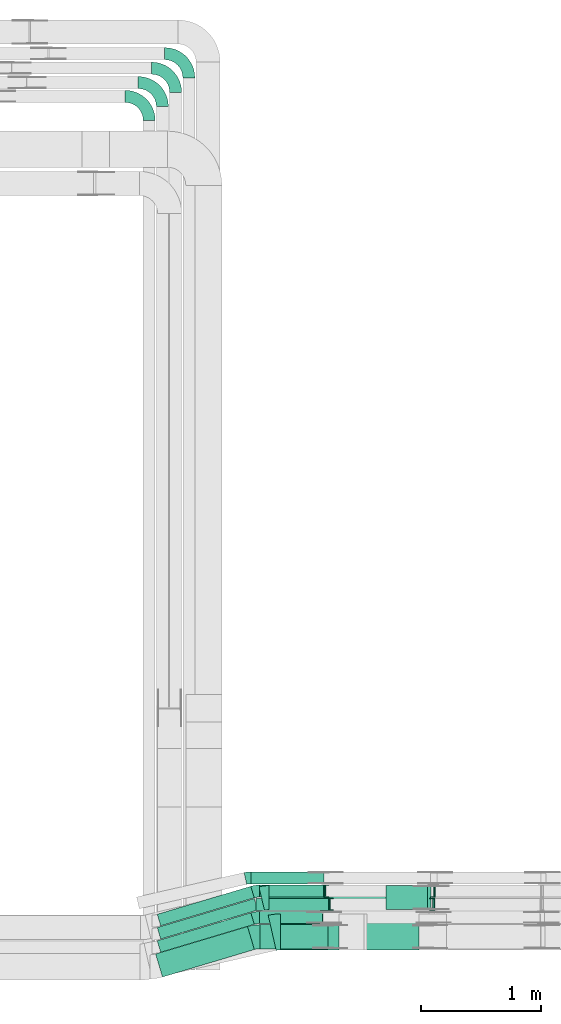
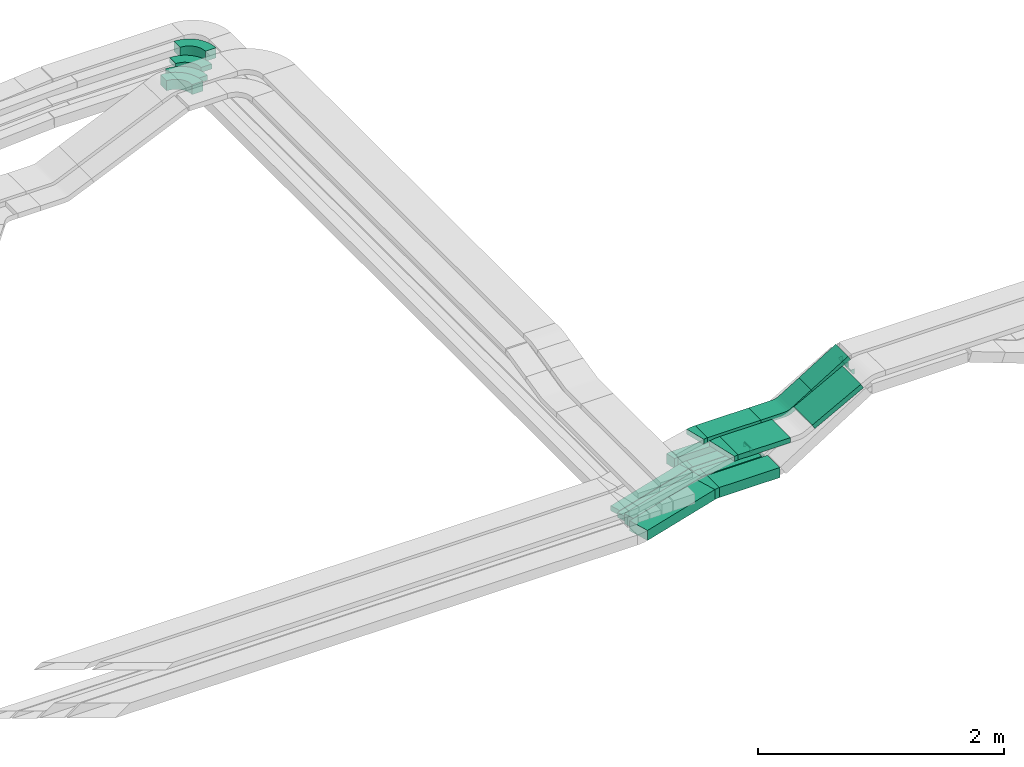
# One storey, part 22 of 28: 15 flow fittings, 13 flow segments.
"""IFC2X3 building model written with IfcOpenShell, lengths in millimetres."""

from ifc_helpers import new_model, entity, si_unit, converted_unit, derived_unit, direction, frame, frame_2d, origin, origin_2d_with_axis, place, context, subcontext, project, spatial, polyline, circle_curve, parameter, trimmed, segment, composite_curve, rectangle, outline, extrude, faceted_brep, source, transform, mapped, material, type_object, type_shapes, element, save


model = new_model("IFC2X3")

# Units and contexts
model_context = context("Model", 3, precision=0.01, world=origin(), true_north=direction((6.12303176911189e-17, 1.0)))
body_context = subcontext(model_context, "Body", "Model", "MODEL_VIEW")
ifc_project = project(units=[si_unit("LENGTHUNIT", "METRE", prefix="MILLI"), si_unit("AREAUNIT", "SQUARE_METRE"), si_unit("VOLUMEUNIT", "CUBIC_METRE"), converted_unit("PLANEANGLEUNIT", "DEGREE", entity("IfcRatioMeasure", 0.0174532925199433), si_unit("PLANEANGLEUNIT", "RADIAN"), dimensions=[0, 0, 0, 0, 0, 0, 0]), si_unit("MASSUNIT", "GRAM", prefix="KILO"), derived_unit("MASSDENSITYUNIT", [(si_unit("MASSUNIT", "GRAM", prefix="KILO"), 1), (si_unit("LENGTHUNIT", "METRE"), -3)]), derived_unit("MOMENTOFINERTIAUNIT", [(si_unit("LENGTHUNIT", "METRE"), 4)]), si_unit("TIMEUNIT", "SECOND"), si_unit("FREQUENCYUNIT", "HERTZ"), si_unit("THERMODYNAMICTEMPERATUREUNIT", "DEGREE_CELSIUS"), derived_unit("THERMALTRANSMITTANCEUNIT", [(si_unit("MASSUNIT", "GRAM", prefix="KILO"), 1), (si_unit("THERMODYNAMICTEMPERATUREUNIT", "KELVIN"), -1), (si_unit("TIMEUNIT", "SECOND"), -3)]), derived_unit("VOLUMETRICFLOWRATEUNIT", [(si_unit("LENGTHUNIT", "METRE"), 3), (si_unit("TIMEUNIT", "SECOND"), -1)]), derived_unit("MASSFLOWRATEUNIT", [(si_unit("MASSUNIT", "GRAM", prefix="KILO"), 1), (si_unit("TIMEUNIT", "SECOND"), -1)]), derived_unit("ROTATIONALFREQUENCYUNIT", [(si_unit("TIMEUNIT", "SECOND"), -1)]), si_unit("ELECTRICCURRENTUNIT", "AMPERE"), si_unit("ELECTRICVOLTAGEUNIT", "VOLT"), si_unit("POWERUNIT", "WATT"), si_unit("FORCEUNIT", "NEWTON", prefix="KILO"), si_unit("ILLUMINANCEUNIT", "LUX"), si_unit("LUMINOUSFLUXUNIT", "LUMEN"), si_unit("LUMINOUSINTENSITYUNIT", "CANDELA"), derived_unit("USERDEFINED", [(si_unit("MASSUNIT", "GRAM", prefix="KILO"), -1), (si_unit("LENGTHUNIT", "METRE"), -2), (si_unit("TIMEUNIT", "SECOND"), 3), (si_unit("LUMINOUSFLUXUNIT", "LUMEN"), 1)]), derived_unit("LINEARVELOCITYUNIT", [(si_unit("LENGTHUNIT", "METRE"), 1), (si_unit("TIMEUNIT", "SECOND"), -1)]), si_unit("PRESSUREUNIT", "PASCAL"), derived_unit("USERDEFINED", [(si_unit("LENGTHUNIT", "METRE"), -2), (si_unit("MASSUNIT", "GRAM", prefix="KILO"), 1), (si_unit("TIMEUNIT", "SECOND"), -2)]), derived_unit("LINEARFORCEUNIT", [(si_unit("MASSUNIT", "GRAM", prefix="KILO"), 1), (si_unit("LENGTHUNIT", "METRE"), 1), (si_unit("TIMEUNIT", "SECOND"), -2), (si_unit("LENGTHUNIT", "METRE"), -1)]), derived_unit("PLANARFORCEUNIT", [(si_unit("MASSUNIT", "GRAM", prefix="KILO"), 1), (si_unit("LENGTHUNIT", "METRE"), 1), (si_unit("TIMEUNIT", "SECOND"), -2), (si_unit("LENGTHUNIT", "METRE"), -2)])], contexts=[model_context])

# Site, building, storey
site_placement = place(None, origin())
site = spatial("IfcSite", under=ifc_project, at=site_placement, CompositionType="ELEMENT")
building_placement = place(site_placement, origin())
building = spatial("IfcBuilding", under=site, at=building_placement, CompositionType="ELEMENT")
storey_placement = place(building_placement, frame((0.0, 0.0, 15900.0)))
storey = spatial("IfcBuildingStorey", under=building, at=storey_placement, CompositionType="ELEMENT", Elevation=15900.0)

# Flow segments
cable_carrier_segment_type = type_object("IfcCableCarrierSegmentType", PredefinedType="CABLETRAYSEGMENT")
flow_segment_1_placement = place(storey_placement, frame((60243.14, 8665.73, 2495.02)))
element("IfcFlowSegment", 1, at=flow_segment_1_placement, inside=storey, type_object=cable_carrier_segment_type, context=body_context, shape_type="SweptSolid", body=[
    extrude(rectangle(XDim=812.342114695417, YDim=100.000000000006, at=origin_2d_with_axis()), frame((403.48, 164.24, 0.0), z_axis=(0.0, 0.0, 1.0), x_axis=(-0.95810498938811, -0.286417229421712, 0.0)), (0.0, 0.0, 1.0), 50.0000000000016),
])
flow_segment_2_placement = place(storey_placement, frame((60243.14, 8555.73, 2495.05)))
element("IfcFlowSegment", 2, at=flow_segment_2_placement, inside=storey, type_object=cable_carrier_segment_type, context=body_context, shape_type="SweptSolid", body=[
    extrude(rectangle(XDim=842.596647110519, YDim=100.000000000006, at=origin_2d_with_axis()), frame((417.97, 168.57, 0.0), z_axis=(0.0, 0.0, 1.0), x_axis=(0.9581049893881, 0.286417229421747, 0.0)), (0.0, 0.0, 1.0), 50.0000000000016),
])
flow_segment_3_placement = place(storey_placement, frame((60243.14, 8445.73, 2500.0)))
element("IfcFlowSegment", 3, at=flow_segment_3_placement, inside=storey, type_object=cable_carrier_segment_type, context=body_context, shape_type="SweptSolid", body=[
    extrude(rectangle(XDim=812.342114695347, YDim=100.000000000004, at=origin_2d_with_axis()), frame((403.48, 164.24, 0.0), z_axis=(0.0, 0.0, 1.0), x_axis=(-0.958104989388097, -0.286417229421757, 0.0)), (0.0, 0.0, 1.0), 99.9999999999989),
])
flow_segment_4_placement = place(storey_placement, frame((60229.55, 8239.92, 2500.0)))
element("IfcFlowSegment", 4, at=flow_segment_4_placement, inside=storey, type_object=cable_carrier_segment_type, context=body_context, shape_type="SweptSolid", body=[
    extrude(rectangle(XDim=797.71484848776, YDim=200.000000000007, at=origin_2d_with_axis()), frame((410.79, 210.05, 0.0), z_axis=(0.0, 0.0, 1.0), x_axis=(0.958104989388095, 0.286417229421762, 0.0)), (0.0, 0.0, 1.0), 99.9999999999989),
])
flow_segment_5_placement = place(storey_placement, frame((61095.01, 8904.97, 2495.02)))
element("IfcFlowSegment", 5, at=flow_segment_5_placement, inside=storey, type_object=cable_carrier_segment_type, context=body_context, shape_type="SweptSolid", body=[
    extrude(rectangle(XDim=534.84490584839, YDim=99.9999999999989, at=origin_2d_with_axis()), frame((267.42, 50.0, 0.0)), (0.0, 0.0, 1.0), 50.0000000000016),
])
flow_segment_6_placement = place(storey_placement, frame((61064.76, 8794.97, 2500.0)))
element("IfcFlowSegment", 6, at=flow_segment_6_placement, inside=storey, type_object=cable_carrier_segment_type, context=body_context, shape_type="SweptSolid", body=[
    extrude(rectangle(XDim=603.13391952185, YDim=100.000000000001, at=origin_2d_with_axis()), frame((301.57, 50.0, 0.0), z_axis=(0.0, 0.0, 1.0), x_axis=(-1.0, 0.0, 0.0)), (0.0, 0.0, 1.0), 50.0000000000016),
])
flow_segment_7_placement = place(storey_placement, frame((61095.01, 8684.97, 2500.0)))
element("IfcFlowSegment", 7, at=flow_segment_7_placement, inside=storey, type_object=cable_carrier_segment_type, context=body_context, shape_type="SweptSolid", body=[
    extrude(rectangle(XDim=521.540062553163, YDim=99.9999999999989, at=origin_2d_with_axis()), frame((260.77, 50.0, 0.0)), (0.0, 0.0, 1.0), 99.9999999999989),
])
flow_segment_8_placement = place(storey_placement, frame((61096.05, 8474.97, 2500.0)))
element("IfcFlowSegment", 8, at=flow_segment_8_placement, inside=storey, type_object=cable_carrier_segment_type, context=body_context, shape_type="SweptSolid", body=[
    extrude(rectangle(XDim=569.341253253551, YDim=200.0, at=origin_2d_with_axis()), frame((284.67, 100.0, 0.0), z_axis=(0.0, 0.0, 1.0), x_axis=(-1.0, 0.0, 0.0)), (0.0, 0.0, 1.0), 99.9999999999989),
])
flow_segment_9_placement = place(storey_placement, frame((61174.21, 8800.15, 2820.0)))
element("IfcFlowSegment", 9, at=flow_segment_9_placement, inside=storey, type_object=cable_carrier_segment_type, context=body_context, shape_type="SweptSolid", body=[
    extrude(rectangle(XDim=499.125355174538, YDim=200.0, at=origin_2d_with_axis()), frame((249.56, 100.0, 0.0)), (0.0, 0.0, 1.0), 50.0000000000016),
])
flow_segment_10_placement = place(storey_placement, frame((61267.59, 8465.15, 2820.0)))
element("IfcFlowSegment", 10, at=flow_segment_10_placement, inside=storey, type_object=cable_carrier_segment_type, context=body_context, shape_type="SweptSolid", body=[
    extrude(rectangle(XDim=489.342035058011, YDim=300.000000000001, at=origin_2d_with_axis()), frame((244.67, 150.0, 0.0)), (0.0, 0.0, 1.0), 50.0000000000016),
])
flow_segment_11_placement = place(storey_placement, frame((61022.43, 9014.97, 2500.0)))
element("IfcFlowSegment", 11, at=flow_segment_11_placement, inside=storey, type_object=cable_carrier_segment_type, context=body_context, shape_type="SweptSolid", body=[
    extrude(rectangle(XDim=607.951662645595, YDim=99.9999999999989, at=origin_2d_with_axis()), frame((303.98, 50.0, 0.0)), (0.0, 0.0, 1.0), 99.9999999999989),
])
flow_segment_12_placement = place(storey_placement, frame((62147.15, 8800.15, 2961.38)))
element("IfcFlowSegment", 12, at=flow_segment_12_placement, inside=storey, type_object=cable_carrier_segment_type, context=body_context, shape_type="SweptSolid", body=[
    extrude(rectangle(XDim=50.000000000001, YDim=200.0, at=origin_2d_with_axis()), frame((13.09, 100.0, 21.3), z_axis=(0.851940405089881, 0.0, 0.523638755417596), x_axis=(-0.523638755417596, 0.0, 0.851940405089881)), (0.0, 0.0, 1.0), 405.830197083303),
])
flow_segment_13_placement = place(storey_placement, frame((61963.27, 8465.15, 2877.86)))
element("IfcFlowSegment", 13, at=flow_segment_13_placement, inside=storey, type_object=cable_carrier_segment_type, context=body_context, shape_type="SweptSolid", body=[
    extrude(rectangle(XDim=49.9999999999993, YDim=299.999999999999, at=origin_2d_with_axis()), frame((11.83, 150.0, 22.02), z_axis=(0.880953567308328, 0.0, 0.473202717919848), x_axis=(-0.473202717919848, 0.0, 0.880953567308328)), (0.0, 0.0, 1.0), 518.229008882918),
])

# Flow fittings
ifc_material = material()
cable_carrier_fitting_type_1 = type_object("IfcCableCarrierFittingType", PredefinedType="NOTDEFINED", material=ifc_material)
shared_shape_1 = source(origin(), body_context, "Body", "Brep", [
    faceted_brep([(-14.14, 25.0, 50.0), (-14.14, 25.0, -50.0), (-14.14, -25.0, -50.0), (-14.14, -25.0, -47.46), (-14.14, 22.46, -47.46), (-14.14, 22.46, 47.46), (-14.14, -25.0, 47.46), (-14.14, -25.0, 50.0), (-1.05, 28.7, 50.0), (25.14, -13.9, 50.0), (25.14, -13.9, 47.46), (0.28, 26.54, 47.46), (0.28, 26.54, -47.46), (25.14, -13.9, -47.46), (25.14, -13.9, -50.0), (-1.05, 28.7, -50.0), (-7.07, 25.0, 50.0), (-7.07, 25.0, -50.0), (7.07, -25.0, -50.0), (7.07, -25.0, -47.46), (-6.35, 22.46, -47.46), (-6.35, 22.46, 47.46), (7.07, -25.0, 47.46), (7.07, -25.0, 50.0)], [[[0, 1, 2, 3, 4, 5, 6, 7]], [[8, 9, 10, 11, 12, 13, 14, 15]], [[1, 0, 16, 17]], [[2, 1, 17, 15, 14, 18]], [[3, 2, 18, 19]], [[4, 3, 19, 13, 12, 20]], [[5, 4, 20, 21]], [[6, 5, 21, 11, 10, 22]], [[7, 6, 22, 23]], [[0, 7, 23, 9, 8, 16]], [[17, 16, 8, 15]], [[19, 18, 14, 13]], [[21, 20, 12, 11]], [[23, 22, 10, 9]]]),
])
type_shapes(cable_carrier_fitting_type_1, [shared_shape_1])
for number, where, z_axis, x_axis in (
    (14, (61682.03, 8844.97, 2525.0), (0.0, -1.0, 0.0), (1.0, 0.0, 0.0)),
    (15, (62536.89, 8844.97, 3050.44), (0.0, 1.0, 0.0), (0.851940405089916, 0.0, 0.52363875541754)),
):
    element("IfcFlowFitting", number, at=place(storey_placement, frame(where, z_axis=z_axis, x_axis=x_axis)), inside=storey, type_object=cable_carrier_fitting_type_1, material=ifc_material, context=body_context, shape_type="MappedRepresentation", body=[
        mapped(shared_shape_1, transform((0.0, 0.0, 0.0), scale=1.0)),
    ])
cable_carrier_fitting_type_2 = type_object("IfcCableCarrierFittingType", PredefinedType="NOTDEFINED", material=ifc_material)
shared_shape_2 = source(origin(), body_context, "Body", "Brep", [
    faceted_brep([(-13.64, 25.0, 50.0), (-13.64, 25.0, -50.0), (-13.64, -25.0, -50.0), (-13.64, -25.0, -47.46), (-13.64, 22.46, -47.46), (-13.64, 22.46, 47.46), (-13.64, -25.0, 47.46), (-13.64, -25.0, 50.0), (-0.94, 28.46, 50.0), (24.45, -14.61, 50.0), (24.45, -14.61, 47.46), (0.35, 26.27, 47.46), (0.35, 26.27, -47.46), (24.45, -14.61, -47.46), (24.45, -14.61, -50.0), (-0.94, 28.46, -50.0), (-6.82, 25.0, 50.0), (-6.82, 25.0, -50.0), (6.82, -25.0, -50.0), (6.82, -25.0, -47.46), (-6.13, 22.46, -47.46), (-6.13, 22.46, 47.46), (6.82, -25.0, 47.46), (6.82, -25.0, 50.0)], [[[0, 1, 2, 3, 4, 5, 6, 7]], [[8, 9, 10, 11, 12, 13, 14, 15]], [[1, 0, 16, 17]], [[2, 1, 17, 15, 14, 18]], [[3, 2, 18, 19]], [[4, 3, 19, 13, 12, 20]], [[5, 4, 20, 21]], [[6, 5, 21, 11, 10, 22]], [[7, 6, 22, 23]], [[0, 7, 23, 9, 8, 16]], [[17, 16, 8, 15]], [[19, 18, 14, 13]], [[21, 20, 12, 11]], [[23, 22, 10, 9]]]),
])
type_shapes(cable_carrier_fitting_type_2, [shared_shape_2])
for number, where, z_axis, x_axis in (
    (16, (61643.49, 8954.97, 2520.02), (0.0, -1.0, 0.0), (1.0, 0.0, 0.0)),
    (17, (62543.34, 8954.97, 3050.44), (0.0, 1.0, 0.0), (0.861478647120901, 0.0, 0.507793797278721)),
):
    element("IfcFlowFitting", number, at=place(storey_placement, frame(where, z_axis=z_axis, x_axis=x_axis)), inside=storey, type_object=cable_carrier_fitting_type_2, material=ifc_material, context=body_context, shape_type="MappedRepresentation", body=[
        mapped(shared_shape_2, transform((0.0, 0.0, 0.0), scale=1.0)),
    ])
cable_carrier_fitting_type_3 = type_object("IfcCableCarrierFittingType", Name="470_DKC_S5_Variable Angle Elbow 0-45:-", PredefinedType="NOTDEFINED", material=ifc_material)
shared_shape_3 = source(origin(), body_context, "Body", "SweptSolid", [
    extrude(outline(composite_curve([segment(polyline([(-100.75, -150.25), (-99.75, -150.25)]), True, "CONTINUOUS"), segment(trimmed(circle_curve(frame_2d((-99.75, 99.75), x_axis=(0.0, -1.0)), 250.0), [parameter(0.0)], [parameter(90.0000000000001)], True, "PARAMETER"), True, "CONTINUOUS"), segment(polyline([(150.25, 99.75), (150.25, 100.75)]), True, "CONTINUOUS"), segment(polyline([(150.25, 100.75), (50.25, 100.75)]), True, "CONTINUOUS"), segment(polyline([(50.25, 100.75), (50.25, 99.75)]), True, "CONTINUOUS"), segment(trimmed(circle_curve(frame_2d((-99.75, 99.75), x_axis=(0.0, -1.0)), 150.0), [parameter(0.0)], [parameter(90.0000000000001)], True, "PARAMETER"), False, "CONTINUOUS"), segment(polyline([(-99.75, -50.25), (-100.75, -50.25)]), True, "CONTINUOUS"), segment(polyline([(-100.75, -50.25), (-100.75, -150.25)]), True, "CONTINUOUS")], self_intersect=False)), frame((-100.25, 100.25, -25.0)), (0.0, 0.0, 1.0), 49.9999999999997),
])
type_shapes(cable_carrier_fitting_type_3, [shared_shape_3])
for number, where, z_axis, x_axis, name in (
    (18, (60396.08, 15799.46, 2685.2), (0.0, 0.0, 1.0), (0.0, 1.0, 0.0), "470_DKC_S5_Variable Angle Elbow 0-45:-"),
    (19, (60286.08, 15679.46, 2685.19), (0.0, 0.0, 1.0), (0.0, 1.0, 0.0), "470_DKC_S5_Variable Angle Elbow 0-45:-"),
):
    element("IfcFlowFitting", number, at=place(storey_placement, frame(where, z_axis=z_axis, x_axis=x_axis)), inside=storey, type_object=cable_carrier_fitting_type_3, material=ifc_material, Name=name, ObjectType="470_DKC_S5_Variable Angle Elbow 0-45:-", context=body_context, shape_type="MappedRepresentation", body=[
        mapped(shared_shape_3, transform((0.0, 0.0, 0.0), scale=1.0)),
    ])
cable_carrier_fitting_type_4 = type_object("IfcCableCarrierFittingType", Name="470_DKC_S5_Variable Angle Elbow 0-45:-", PredefinedType="NOTDEFINED", material=ifc_material)
shared_shape_4 = source(origin(), body_context, "Body", "SweptSolid", [
    extrude(outline(composite_curve([segment(polyline([(-29.63, -54.26), (-28.63, -54.26)]), True, "CONTINUOUS"), segment(trimmed(circle_curve(frame_2d((-28.63, 195.74), x_axis=(0.0, -1.0)), 250.0), [parameter(0.0)], [parameter(16.6435818354741)], True, "PARAMETER"), True, "CONTINUOUS"), segment(polyline([(42.97, -43.79), (43.93, -43.5)]), True, "CONTINUOUS"), segment(polyline([(43.93, -43.5), (15.29, 52.31)]), True, "CONTINUOUS"), segment(polyline([(15.29, 52.31), (14.33, 52.02)]), True, "CONTINUOUS"), segment(trimmed(circle_curve(frame_2d((-28.63, 195.74), x_axis=(0.0, -1.0)), 150.0), [parameter(0.0)], [parameter(16.6435818354741)], True, "PARAMETER"), False, "CONTINUOUS"), segment(polyline([(-28.63, 45.74), (-29.63, 45.74)]), True, "CONTINUOUS"), segment(polyline([(-29.63, 45.74), (-29.63, -54.26)]), True, "CONTINUOUS")], self_intersect=False)), frame((-0.62, 4.26, -25.0)), (0.0, 0.0, 1.0), 50.0000000000001),
])
type_shapes(cable_carrier_fitting_type_4, [shared_shape_4])
flow_fitting_1_placement = place(storey_placement, frame((61064.76, 8954.97, 2520.02), z_axis=(0.0, 0.0, 1.0), x_axis=(-1.0, 0.0, 0.0)))
element("IfcFlowFitting", 20, at=flow_fitting_1_placement, inside=storey, type_object=cable_carrier_fitting_type_4, material=ifc_material, Name="470_DKC_S5_Variable Angle Elbow 0-45:-", ObjectType="470_DKC_S5_Variable Angle Elbow 0-45:-", context=body_context, shape_type="MappedRepresentation", body=[
    mapped(shared_shape_4, transform((0.0, 0.0, 0.0), scale=1.0)),
])
cable_carrier_fitting_type_5 = type_object("IfcCableCarrierFittingType", Name="470_DKC_S5_Variable Angle Elbow 0-45:-", PredefinedType="NOTDEFINED", material=ifc_material)
shared_shape_5 = source(origin(), body_context, "Body", "SweptSolid", [
    extrude(outline(composite_curve([segment(polyline([(-29.63, -54.26), (-28.63, -54.26)]), True, "CONTINUOUS"), segment(trimmed(circle_curve(frame_2d((-28.63, 195.74), x_axis=(0.0, -1.0)), 250.0), [parameter(0.0)], [parameter(16.6435818354755)], True, "PARAMETER"), True, "CONTINUOUS"), segment(polyline([(42.97, -43.79), (43.93, -43.5)]), True, "CONTINUOUS"), segment(polyline([(43.93, -43.5), (15.29, 52.31)]), True, "CONTINUOUS"), segment(polyline([(15.29, 52.31), (14.33, 52.02)]), True, "CONTINUOUS"), segment(trimmed(circle_curve(frame_2d((-28.63, 195.74), x_axis=(0.0, -1.0)), 150.0), [parameter(0.0)], [parameter(16.6435818354755)], True, "PARAMETER"), False, "CONTINUOUS"), segment(polyline([(-28.63, 45.74), (-29.63, 45.74)]), True, "CONTINUOUS"), segment(polyline([(-29.63, 45.74), (-29.63, -54.26)]), True, "CONTINUOUS")], self_intersect=False)), frame((-0.62, 4.26, -50.0)), (0.0, 0.0, 1.0), 100.0),
])
type_shapes(cable_carrier_fitting_type_5, [shared_shape_5])
flow_fitting_2_placement = place(storey_placement, frame((61064.76, 8734.97, 2550.0), z_axis=(0.0, 0.0, 1.0), x_axis=(-1.0, 0.0, 0.0)))
element("IfcFlowFitting", 21, at=flow_fitting_2_placement, inside=storey, type_object=cable_carrier_fitting_type_5, material=ifc_material, Name="470_DKC_S5_Variable Angle Elbow 0-45:-", ObjectType="470_DKC_S5_Variable Angle Elbow 0-45:-", context=body_context, shape_type="MappedRepresentation", body=[
    mapped(shared_shape_5, transform((0.0, 0.0, 0.0), scale=1.0)),
])
cable_carrier_fitting_type_6 = type_object("IfcCableCarrierFittingType", Name="470_DKC_S5_Variable Angle Elbow 0-45:-", PredefinedType="NOTDEFINED", material=ifc_material)
shared_shape_6 = source(origin(), body_context, "Body", "SweptSolid", [
    extrude(outline(composite_curve([segment(polyline([(-36.79, -105.31), (-35.79, -105.31)]), True, "CONTINUOUS"), segment(trimmed(circle_curve(frame_2d((-35.79, 244.69), x_axis=(0.0, -1.0)), 350.0), [parameter(0.0)], [parameter(16.6435818354755)], True, "PARAMETER"), True, "CONTINUOUS"), segment(polyline([(64.45, -90.65), (65.41, -90.36)]), True, "CONTINUOUS"), segment(polyline([(65.41, -90.36), (8.13, 101.26)]), True, "CONTINUOUS"), segment(polyline([(8.13, 101.26), (7.17, 100.98)]), True, "CONTINUOUS"), segment(trimmed(circle_curve(frame_2d((-35.79, 244.69), x_axis=(0.0, -1.0)), 150.0), [parameter(0.0)], [parameter(16.6435818354755)], True, "PARAMETER"), False, "CONTINUOUS"), segment(polyline([(-35.79, 94.69), (-36.79, 94.69)]), True, "CONTINUOUS"), segment(polyline([(-36.79, 94.69), (-36.79, -105.31)]), True, "CONTINUOUS")], self_intersect=False)), frame((-0.78, 5.31, -50.0)), (0.0, 0.0, 1.0), 100.0),
])
type_shapes(cable_carrier_fitting_type_6, [shared_shape_6])
flow_fitting_3_placement = place(storey_placement, frame((61058.48, 8574.97, 2550.0), z_axis=(0.0, 0.0, 1.0), x_axis=(-1.0, 0.0, 0.0)))
element("IfcFlowFitting", 22, at=flow_fitting_3_placement, inside=storey, type_object=cable_carrier_fitting_type_6, material=ifc_material, Name="470_DKC_S5_Variable Angle Elbow 0-45:-", ObjectType="470_DKC_S5_Variable Angle Elbow 0-45:-", context=body_context, shape_type="MappedRepresentation", body=[
    mapped(shared_shape_6, transform((0.0, 0.0, 0.0), scale=1.0)),
])
cable_carrier_fitting_type_7 = type_object("IfcCableCarrierFittingType", Name="470_DKC_S5_Variable Angle Elbow 0-45:-", PredefinedType="NOTDEFINED", material=ifc_material)
shared_shape_7 = source(origin(), body_context, "Body", "SweptSolid", [
    extrude(outline(composite_curve([segment(polyline([(-31.12, -103.74), (-30.12, -103.74)]), True, "CONTINUOUS"), segment(trimmed(circle_curve(frame_2d((-30.12, 246.26), x_axis=(0.0, -1.0)), 350.0), [parameter(0.0)], [parameter(13.9444078794154)], True, "PARAMETER"), True, "CONTINUOUS"), segment(polyline([(54.23, -93.43), (55.2, -93.19)]), True, "CONTINUOUS"), segment(polyline([(55.2, -93.19), (7.0, 100.92)]), True, "CONTINUOUS"), segment(polyline([(7.0, 100.92), (6.03, 100.68)]), True, "CONTINUOUS"), segment(trimmed(circle_curve(frame_2d((-30.12, 246.26), x_axis=(0.0, -1.0)), 150.0), [parameter(0.0)], [parameter(13.9444078794154)], True, "PARAMETER"), False, "CONTINUOUS"), segment(polyline([(-30.12, 96.26), (-31.12, 96.26)]), True, "CONTINUOUS"), segment(polyline([(-31.12, 96.26), (-31.12, -103.74)]), True, "CONTINUOUS")], self_intersect=False)), frame((-0.46, 3.74, -25.0)), (0.0, 0.0, 1.0), 50.0000000000004),
])
type_shapes(cable_carrier_fitting_type_7, [shared_shape_7])
flow_fitting_4_placement = place(storey_placement, frame((61142.63, 8900.15, 2845.0), z_axis=(0.0, 0.0, 1.0), x_axis=(-1.0, 0.0, 0.0)))
element("IfcFlowFitting", 23, at=flow_fitting_4_placement, inside=storey, type_object=cable_carrier_fitting_type_7, material=ifc_material, Name="470_DKC_S5_Variable Angle Elbow 0-45:-", ObjectType="470_DKC_S5_Variable Angle Elbow 0-45:-", context=body_context, shape_type="MappedRepresentation", body=[
    mapped(shared_shape_7, transform((0.0, 0.0, 0.0), scale=1.0)),
])
cable_carrier_fitting_type_8 = type_object("IfcCableCarrierFittingType", Name="470_DKC_S5_Variable Angle Elbow 0-45:-", PredefinedType="NOTDEFINED", material=ifc_material)
shared_shape_8 = source(origin(), body_context, "Body", "SweptSolid", [
    extrude(outline(composite_curve([segment(polyline([(-34.24, -153.79), (-33.24, -153.79)]), True, "CONTINUOUS"), segment(trimmed(circle_curve(frame_2d((-33.24, 296.21), x_axis=(0.0, -1.0)), 450.0), [parameter(0.0)], [parameter(12.8070045345911)], True, "PARAMETER"), True, "CONTINUOUS"), segment(polyline([(66.51, -142.59), (67.48, -142.37)]), True, "CONTINUOUS"), segment(polyline([(67.48, -142.37), (0.98, 150.17)]), True, "CONTINUOUS"), segment(polyline([(0.98, 150.17), (0.01, 149.94)]), True, "CONTINUOUS"), segment(trimmed(circle_curve(frame_2d((-33.24, 296.21), x_axis=(0.0, -1.0)), 150.0), [parameter(0.0)], [parameter(12.8070045345911)], True, "PARAMETER"), False, "CONTINUOUS"), segment(polyline([(-33.24, 146.21), (-34.24, 146.21)]), True, "CONTINUOUS"), segment(polyline([(-34.24, 146.21), (-34.24, -153.79)]), True, "CONTINUOUS")], self_intersect=False)), frame((-0.43, 3.79, -25.0)), (0.0, 0.0, 1.0), 49.9999999999996),
])
type_shapes(cable_carrier_fitting_type_8, [shared_shape_8])
flow_fitting_5_placement = place(storey_placement, frame((61232.92, 8615.15, 2845.0), z_axis=(0.0, 0.0, 1.0), x_axis=(-1.0, 0.0, 0.0)))
element("IfcFlowFitting", 24, at=flow_fitting_5_placement, inside=storey, type_object=cable_carrier_fitting_type_8, material=ifc_material, Name="470_DKC_S5_Variable Angle Elbow 0-45:-", ObjectType="470_DKC_S5_Variable Angle Elbow 0-45:-", context=body_context, shape_type="MappedRepresentation", body=[
    mapped(shared_shape_8, transform((0.0, 0.0, 0.0), scale=1.0)),
])
cable_carrier_fitting_type_9 = type_object("IfcCableCarrierFittingType", Name="470_DKC_S5_Variable Angle Elbow 0-45:-", PredefinedType="NOTDEFINED", material=ifc_material)
shared_shape_9 = source(origin(), body_context, "Body", "SweptSolid", [
    extrude(outline(composite_curve([segment(polyline([(-100.75, -150.25), (-99.75, -150.25)]), True, "CONTINUOUS"), segment(trimmed(circle_curve(frame_2d((-99.75, 99.75), x_axis=(0.0, -1.0)), 250.0), [parameter(0.0)], [parameter(90.0000000000001)], True, "PARAMETER"), True, "CONTINUOUS"), segment(polyline([(150.25, 99.75), (150.25, 100.75)]), True, "CONTINUOUS"), segment(polyline([(150.25, 100.75), (50.25, 100.75)]), True, "CONTINUOUS"), segment(polyline([(50.25, 100.75), (50.25, 99.75)]), True, "CONTINUOUS"), segment(trimmed(circle_curve(frame_2d((-99.75, 99.75), x_axis=(0.0, -1.0)), 150.0), [parameter(0.0)], [parameter(90.0000000000001)], True, "PARAMETER"), False, "CONTINUOUS"), segment(polyline([(-99.75, -50.25), (-100.75, -50.25)]), True, "CONTINUOUS"), segment(polyline([(-100.75, -50.25), (-100.75, -150.25)]), True, "CONTINUOUS")], self_intersect=False)), frame((-100.25, 100.25, -50.0)), (0.0, 0.0, 1.0), 100.0),
])
type_shapes(cable_carrier_fitting_type_9, [shared_shape_9])
for number, where, z_axis, x_axis, name in (
    (25, (60506.08, 15919.99, 2710.0), (0.0, 0.0, 1.0), (0.0, 1.0, 0.0), "470_DKC_S5_Variable Angle Elbow 0-45:-"),
    (26, (60176.08, 15564.99, 2710.0), (0.0, 0.0, 1.0), (0.0, 1.0, 0.0), "470_DKC_S5_Variable Angle Elbow 0-45:-"),
):
    element("IfcFlowFitting", number, at=place(storey_placement, frame(where, z_axis=z_axis, x_axis=x_axis)), inside=storey, type_object=cable_carrier_fitting_type_9, material=ifc_material, Name=name, ObjectType="470_DKC_S5_Variable Angle Elbow 0-45:-", context=body_context, shape_type="MappedRepresentation", body=[
        mapped(shared_shape_9, transform((0.0, 0.0, 0.0), scale=1.0)),
    ])
cable_carrier_fitting_type_10 = type_object("IfcCableCarrierFittingType", Name="470_DKC_S5_Variable Angle Elbow 0-45:-", PredefinedType="NOTDEFINED", material=ifc_material)
shared_shape_10 = source(origin(), body_context, "Body", "SweptSolid", [
    extrude(outline(composite_curve([segment(polyline([(-23.16, -52.54), (-22.16, -52.54)]), True, "CONTINUOUS"), segment(trimmed(circle_curve(frame_2d((-22.16, 197.46), x_axis=(0.0, -1.0)), 250.0), [parameter(0.0)], [parameter(12.8070045345923)], True, "PARAMETER"), True, "CONTINUOUS"), segment(polyline([(33.26, -46.32), (34.23, -46.1)]), True, "CONTINUOUS"), segment(polyline([(34.23, -46.1), (12.06, 51.41)]), True, "CONTINUOUS"), segment(polyline([(12.06, 51.41), (11.09, 51.19)]), True, "CONTINUOUS"), segment(trimmed(circle_curve(frame_2d((-22.16, 197.46), x_axis=(0.0, -1.0)), 150.0), [parameter(0.0)], [parameter(12.8070045345923)], True, "PARAMETER"), False, "CONTINUOUS"), segment(polyline([(-22.16, 47.46), (-23.16, 47.46)]), True, "CONTINUOUS"), segment(polyline([(-23.16, 47.46), (-23.16, -52.54)]), True, "CONTINUOUS")], self_intersect=False)), frame((-0.29, 2.54, -50.0)), (0.0, 0.0, 1.0), 100.0),
])
type_shapes(cable_carrier_fitting_type_10, [shared_shape_10])
flow_fitting_6_placement = place(storey_placement, frame((60998.99, 9064.97, 2550.0), z_axis=(0.0, 0.0, 1.0), x_axis=(-1.0, 0.0, 0.0)))
element("IfcFlowFitting", 27, at=flow_fitting_6_placement, inside=storey, type_object=cable_carrier_fitting_type_10, material=ifc_material, Name="470_DKC_S5_Variable Angle Elbow 0-45:-", ObjectType="470_DKC_S5_Variable Angle Elbow 0-45:-", context=body_context, shape_type="MappedRepresentation", body=[
    mapped(shared_shape_10, transform((0.0, 0.0, 0.0), scale=1.0)),
])
cable_carrier_fitting_type_11 = type_object("IfcCableCarrierFittingType", Name="470_DKC_S5_CS 90 internal vertical angle:-", PredefinedType="NOTDEFINED", material=ifc_material)
shared_shape_11 = source(origin(), body_context, "Body", "SweptSolid", [
    extrude(outline(composite_curve([segment(polyline([(-251.72, -64.6), (-28.39, -64.6)]), True, "CONTINUOUS"), segment(trimmed(circle_curve(frame_2d((-28.39, 100.4), x_axis=(0.0, -1.0)), 164.999999999999), [parameter(0.0)], [parameter(31.5766500645029)], True, "PARAMETER"), True, "CONTINUOUS"), segment(polyline([(58.01, -40.17), (248.28, 76.78)]), True, "CONTINUOUS"), segment(polyline([(248.28, 76.78), (222.1, 119.37)]), True, "CONTINUOUS"), segment(polyline([(222.1, 119.37), (31.83, 2.43)]), True, "CONTINUOUS"), segment(trimmed(circle_curve(frame_2d((-28.39, 100.4), x_axis=(0.0, -1.0)), 114.999999999999), [parameter(0.0)], [parameter(31.5766500645029)], True, "PARAMETER"), False, "CONTINUOUS"), segment(polyline([(-28.39, -14.6), (-251.72, -14.6)]), True, "CONTINUOUS"), segment(polyline([(-251.72, -14.6), (-251.72, -64.6)]), True, "CONTINUOUS")], self_intersect=False)), frame((-11.2, 39.6, -100.0)), (0.0, 0.0, 1.0), 200.0),
])
type_shapes(cable_carrier_fitting_type_11, [shared_shape_11])
flow_fitting_7_placement = place(storey_placement, frame((61936.25, 8900.15, 2845.0), z_axis=(0.0, 1.0, 0.0), x_axis=(-0.851940405089897, 0.0, -0.52363875541757)))
element("IfcFlowFitting", 28, at=flow_fitting_7_placement, inside=storey, type_object=cable_carrier_fitting_type_11, material=ifc_material, Name="470_DKC_S5_CS 90 internal vertical angle:-", ObjectType="470_DKC_S5_CS 90 internal vertical angle:-", context=body_context, shape_type="MappedRepresentation", body=[
    mapped(shared_shape_11, transform((0.0, 0.0, 0.0), scale=1.0)),
])

save(model, "model.ifc")
